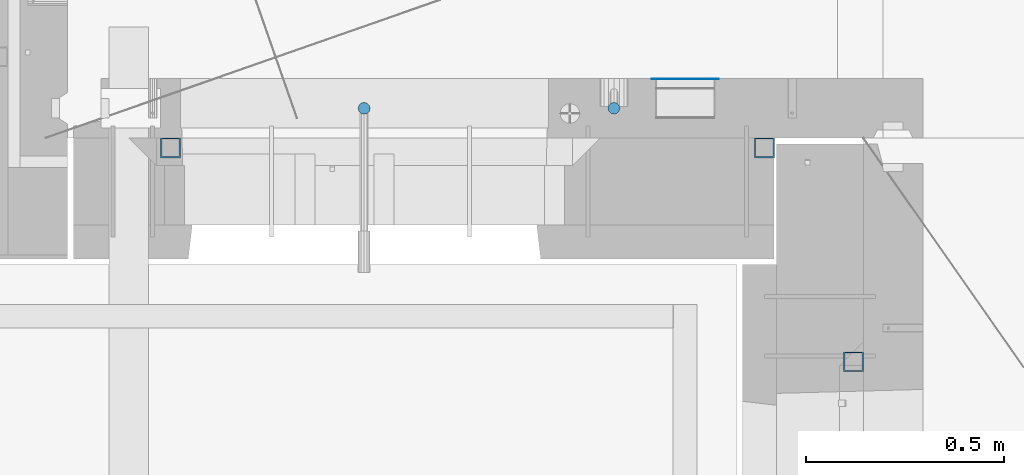
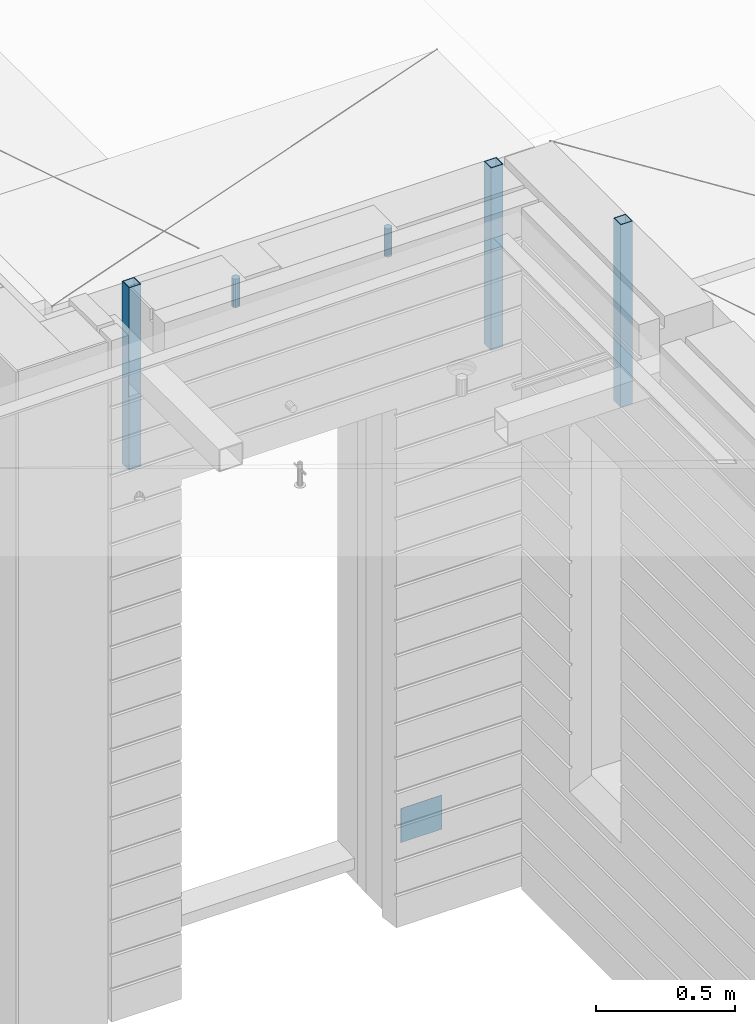
# One storey, part 11 of 334: 6 columns, 6 elements without a shape of their own.
"""IFC2X3 building model written with IfcOpenShell, lengths in millimetres."""

import ifcopenshell
import ifcopenshell.guid

model = None  # the IFC model being written
_history = None  # IfcOwnerHistory: only IFC2X3 demands one
_inside = {}  # id of a spatial element -> (the spatial element, [elements in it])
_under = {}  # id of a project, library or spatial element -> (it, [spatial elements below it])
_declared = {}  # id of a project -> (the project, [libraries it declares])
_typed = {}  # id of a type object -> (the type object, [elements of that type])
_made_of = {}  # id of a material, layer set ... -> (it, [elements and type objects made of it])


def new_model(schema):
    """Start an empty IFC model of exactly this schema.

    Asked for "IFC4X3", IfcOpenShell would pick the latest addendum, in which some entities
    have other attributes; the version numbers below select the first issue.
    IFC2X3 requires an IfcOwnerHistory on every rooted entity: one is made here for all.
    """
    global model, _history
    if schema == "IFC4X3":
        model = ifcopenshell.file(schema_version=(4, 3, 0, 0))
    else:
        model = ifcopenshell.file(schema=schema)
    _inside.clear()
    _under.clear()
    _declared.clear()
    _typed.clear()
    _made_of.clear()
    _history = None
    if model.schema == "IFC2X3":
        org = make("IfcOrganization", Name="unknown")
        user = make(
            "IfcPersonAndOrganization",
            ThePerson=make("IfcPerson", FamilyName="unknown"),
            TheOrganization=org,
        )
        app = make(
            "IfcApplication",
            ApplicationDeveloper=org,
            Version="unknown",
            ApplicationFullName="unknown",
            ApplicationIdentifier="unknown",
        )
        _history = make(
            "IfcOwnerHistory",
            OwningUser=user,
            OwningApplication=app,
            ChangeAction="ADDED",
            CreationDate=0,
        )
    return model


def make(cls, **values):
    """One entity of the class cls with the attributes given. An attribute that is None is left unset."""
    return model.create_entity(
        cls, **{name: value for name, value in values.items() if value is not None}
    )


def rooted(cls, **values):
    """An entity with a GlobalId (a new one), such as an element, a storey or a relation."""
    return make(cls, GlobalId=ifcopenshell.guid.new(), OwnerHistory=_history, **values)


def si_unit(unit_type, name, prefix=None):
    """IfcSIUnit, for example si_unit("LENGTHUNIT", "METRE", prefix="MILLI")."""
    return make("IfcSIUnit", UnitType=unit_type, Prefix=prefix, Name=name)


def assignment(units):
    """IfcUnitAssignment: the units of a project."""
    return None if units is None else make("IfcUnitAssignment", Units=units)


def point(xyz):
    """IfcCartesianPoint."""
    return None if xyz is None else make("IfcCartesianPoint", Coordinates=xyz)


def direction(xyz):
    """IfcDirection."""
    return None if xyz is None else make("IfcDirection", DirectionRatios=xyz)


def frame(location, z_axis=None, x_axis=None):
    """IfcAxis2Placement3D, a coordinate frame: its origin and axes. An axis left out is left unset."""
    return make(
        "IfcAxis2Placement3D",
        Location=point(location),
        Axis=direction(z_axis),
        RefDirection=direction(x_axis),
    )


def origin_with_axes():
    """The frame at (0, 0, 0) with the z axis (0, 0, 1) and the x axis (1, 0, 0) written out."""
    return frame((0.0, 0.0, 0.0), z_axis=(0.0, 0.0, 1.0), x_axis=(1.0, 0.0, 0.0))


def place(relative_to, where):
    """IfcLocalPlacement: puts the frame where relative to a parent placement (None: the world)."""
    return make(
        "IfcLocalPlacement", PlacementRelTo=relative_to, RelativePlacement=where
    )


def context(
    kind, dimensions, precision=None, world=None, true_north=None, identifier=None
):
    """IfcGeometricRepresentationContext, for example the 3D "Model" context."""
    return make(
        "IfcGeometricRepresentationContext",
        ContextIdentifier=identifier,
        ContextType=kind,
        CoordinateSpaceDimension=dimensions,
        Precision=precision,
        WorldCoordinateSystem=world,
        TrueNorth=true_north,
    )


def subcontext(parent, identifier, kind, view, scale=None):
    """IfcGeometricRepresentationSubContext, for example "Body" below "Model"."""
    return make(
        "IfcGeometricRepresentationSubContext",
        ContextIdentifier=identifier,
        ContextType=kind,
        ParentContext=parent,
        TargetScale=scale,
        TargetView=view,
    )


def project(units=None, contexts=None):
    """IfcProject with its units and contexts."""
    return rooted(
        "IfcProject",
        Name="project",
        RepresentationContexts=contexts,
        UnitsInContext=assignment(units),
    )


def spatial(cls, under=None, at=None, **own):
    """A site, building, storey or space (cls), placed at a placement, below another one or the project."""
    s = rooted(cls, ObjectPlacement=at, **own)
    if under is not None:
        _under.setdefault(under.id(), (under, []))[1].append(s)
    return s


def faces_of(points, faces, orient=None, outer=None):
    """IfcFace entities. A face is a list of loops; a loop is a list of indices into points, from 0.

    orient and outer hold one flag for each loop. By default every Orientation is true, the
    first loop of a face is its IfcFaceOuterBound and the others are IfcFaceBound.
    """
    made = []
    for i, loops in enumerate(faces):
        bounds = []
        for j, loop in enumerate(loops):
            is_outer = j == 0 if outer is None else outer[i][j]
            bounds.append(
                make(
                    "IfcFaceOuterBound" if is_outer else "IfcFaceBound",
                    Bound=make("IfcPolyLoop", Polygon=[points[k] for k in loop]),
                    Orientation=True if orient is None else orient[i][j],
                )
            )
        made.append(make("IfcFace", Bounds=bounds))
    return made


def faceted_brep(points, faces, orient=None, outer=None, voids=None):
    """IfcFacetedBrep: a solid bounded by flat faces; with voids (closed shells), ...WithVoids."""
    shared = [point(p) for p in points]
    hull = make("IfcClosedShell", CfsFaces=faces_of(shared, faces, orient, outer))
    if voids is None:
        return make("IfcFacetedBrep", Outer=hull)
    return make(
        "IfcFacetedBrepWithVoids",
        Outer=hull,
        Voids=[
            make(cls, CfsFaces=faces_of(shared, fs, o, b)) for cls, fs, o, b in voids
        ],
    )


def shape(context_of_items, identifier, shape_type, items):
    """IfcShapeRepresentation: the items that make up one representation, for example the "Body"."""
    return make(
        "IfcShapeRepresentation",
        ContextOfItems=context_of_items,
        RepresentationIdentifier=identifier,
        RepresentationType=shape_type,
        Items=items,
    )


def material(Name=None, Category=None):
    """IfcMaterial."""
    return make("IfcMaterial", Name=Name, Category=Category)


def made_of(thing, what):
    """Note that an element or type object is made of a material, layer set ...; save() writes the relation."""
    if what is not None:
        _made_of.setdefault(what.id(), (what, []))[1].append(thing)
    return thing


def type_object(cls, material=None, **own):
    """A type object (cls), such as IfcWallType, which elements share."""
    return made_of(rooted(cls, **own), material)


def element(
    cls,
    number,
    at=None,
    inside=None,
    cuts=None,
    type_object=None,
    material=None,
    context=None,
    identifier="Body",
    shape_type=None,
    held_by="IfcProductDefinitionShape",
    body=None,
    shapes=None,
    **own,
):
    """One element of the class cls, such as IfcWall. Its Tag is "e" and its number.

    at: its placement. inside: the storey or other place that contains it. cuts: it is an
    opening in that element (IfcRelVoidsElement). A single representation is given by context,
    identifier, shape_type and body (its items); several are given by shapes. held_by: the class
    of the entity that holds the representations. save() writes the other relations.
    """
    e = rooted(cls, Tag="e%d" % number, ObjectPlacement=at, **own)
    if body is not None:
        shapes = [shape(context, identifier, shape_type, body)]
    if shapes is not None:
        e.Representation = make(held_by, Representations=shapes)
    if inside is not None:
        _inside.setdefault(inside.id(), (inside, []))[1].append(e)
    if cuts is not None:
        rooted(
            "IfcRelVoidsElement", RelatingBuildingElement=cuts, RelatedOpeningElement=e
        )
    if type_object is not None:
        _typed.setdefault(type_object.id(), (type_object, []))[1].append(e)
    return made_of(e, material)


def aggregate(whole, parts):
    """IfcRelAggregates: a whole, such as a stair, and the parts it consists of."""
    return rooted("IfcRelAggregates", RelatingObject=whole, RelatedObjects=parts)


def save(model, path):
    """Write the relations noted so far, then the file.

    IfcRelAggregates (storeys below a building ...), IfcRelContainedInSpatialStructure (elements
    in a storey), IfcRelDefinesByType, IfcRelAssociatesMaterial and IfcRelDeclares: one each for
    every whole, place, type object, material and project.
    """
    for whole, parts in _under.values():
        aggregate(whole, parts)
    for where, things in _inside.values():
        rooted(
            "IfcRelContainedInSpatialStructure",
            RelatedElements=things,
            RelatingStructure=where,
        )
    for kind, things in _typed.values():
        rooted("IfcRelDefinesByType", RelatedObjects=things, RelatingType=kind)
    for what, things in _made_of.values():
        rooted("IfcRelAssociatesMaterial", RelatedObjects=things, RelatingMaterial=what)
    for by, libraries in _declared.values():
        rooted("IfcRelDeclares", RelatingContext=by, RelatedDefinitions=libraries)
    model.write(path)


model = new_model("IFC2X3")

# Units and contexts
model_context = context("Model", 3, precision=1e-05, world=origin_with_axes())
body_context = subcontext(model_context, "Body", "Model", "MODEL_VIEW")
ifc_project = project(units=[si_unit("LENGTHUNIT", "METRE", prefix="MILLI"), si_unit("AREAUNIT", "SQUARE_METRE"), si_unit("VOLUMEUNIT", "CUBIC_METRE"), si_unit("MASSUNIT", "GRAM", prefix="KILO"), si_unit("TIMEUNIT", "SECOND"), si_unit("PLANEANGLEUNIT", "RADIAN"), si_unit("SOLIDANGLEUNIT", "STERADIAN"), si_unit("THERMODYNAMICTEMPERATUREUNIT", "DEGREE_CELSIUS"), si_unit("LUMINOUSINTENSITYUNIT", "LUMEN")], contexts=[model_context])

# Site, building, storey
site_placement = place(None, origin_with_axes())
site = spatial("IfcSite", under=ifc_project, at=site_placement, CompositionType="ELEMENT")
building_placement = place(site_placement, origin_with_axes())
building = spatial("IfcBuilding", under=site, at=building_placement, CompositionType="ELEMENT")
storey_placement = place(building_placement, origin_with_axes())
storey = spatial("IfcBuildingStorey", under=building, at=storey_placement, Name="3", CompositionType="ELEMENT", Elevation=0.0)

# Assemblies, columns
assembly_1_placement = place(storey_placement, origin_with_axes())
assembly_1 = element("IfcElementAssembly", 1, at=assembly_1_placement, inside=storey, AssemblyPlace="NOTDEFINED", PredefinedType="REINFORCEMENT_UNIT")
ifc_material_1 = material()
column_type_1 = type_object("IfcColumnType", Name="D30", PredefinedType="NOTDEFINED")
column_1_placement = place(assembly_1_placement, frame((9379.99827996565, 11025.0, 90407.5), z_axis=(0.0, -1.0, 0.0), x_axis=(0.0, 0.0, 1.0)))
column_1 = element("IfcColumn", 2, at=column_1_placement, type_object=column_type_1, material=ifc_material_1, ObjectType="D30", context=body_context, shape_type="Brep", body=[
    faceted_brep([(0.0, -15.0, 0.0), (0.0, -12.9903810567666, -7.5), (125.0, -12.9903810567666, -7.5), (125.0, -15.0, 0.0), (0.0, -7.5, -12.9903810567666), (125.0, -7.5, -12.9903810567666), (0.0, 0.0, -15.0), (125.0, 0.0, -15.0), (0.0, 7.5, -12.9903810567666), (125.0, 7.5, -12.9903810567666), (0.0, 12.9903810567666, -7.5), (125.0, 12.9903810567666, -7.5), (0.0, 15.0, 0.0), (125.0, 15.0, 0.0), (0.0, 12.9903810567666, 7.5), (125.0, 12.9903810567666, 7.5), (0.0, 7.5, 12.9903810567666), (125.0, 7.5, 12.9903810567666), (0.0, 0.0, 15.0), (125.0, 0.0, 15.0), (0.0, -7.5, 12.9903810567666), (125.0, -7.5, 12.9903810567666), (0.0, -12.9903810567666, 7.5), (125.0, -12.9903810567666, 7.5)], [[[0, 1, 2, 3]], [[1, 4, 5, 2]], [[4, 6, 7, 5]], [[6, 8, 9, 7]], [[8, 10, 11, 9]], [[10, 12, 13, 11]], [[12, 14, 15, 13]], [[14, 16, 17, 15]], [[16, 18, 19, 17]], [[18, 20, 21, 19]], [[20, 22, 23, 21]], [[22, 0, 3, 23]], [[5, 7, 9, 11, 13, 15, 17, 19, 21, 23, 3, 2]], [[22, 20, 18, 16, 14, 12, 10, 8, 6, 4, 1, 0]]]),
])
column_2_placement = place(assembly_1_placement, frame((8748.99633326467, 11025.0000000071, 90407.5), z_axis=(0.0, 1.0, 0.0), x_axis=(0.0, 0.0, 1.0)))
column_2 = element("IfcColumn", 3, at=column_2_placement, type_object=column_type_1, material=ifc_material_1, ObjectType="D30", context=body_context, shape_type="Brep", body=[
    faceted_brep([(0.0, -15.0, 0.0), (0.0, -12.9903810567666, -7.5), (125.0, -12.9903810567666, -7.5), (125.0, -15.0, 0.0), (0.0, -7.5, -12.9903810567666), (125.0, -7.5, -12.9903810567666), (0.0, 0.0, -15.0), (125.0, 0.0, -15.0), (0.0, 7.5, -12.9903810567666), (125.0, 7.5, -12.9903810567666), (0.0, 12.9903810567666, -7.5), (125.0, 12.9903810567666, -7.5), (0.0, 15.0, 0.0), (125.0, 15.0, 0.0), (0.0, 12.9903810567666, 7.5), (125.0, 12.9903810567666, 7.5), (0.0, 7.5, 12.9903810567666), (125.0, 7.5, 12.9903810567666), (0.0, 0.0, 15.0), (125.0, 0.0, 15.0), (0.0, -7.5, 12.9903810567666), (125.0, -7.5, 12.9903810567666), (0.0, -12.9903810567666, 7.5), (125.0, -12.9903810567666, 7.5)], [[[0, 1, 2, 3]], [[1, 4, 5, 2]], [[4, 6, 7, 5]], [[6, 8, 9, 7]], [[8, 10, 11, 9]], [[10, 12, 13, 11]], [[12, 14, 15, 13]], [[14, 16, 17, 15]], [[16, 18, 19, 17]], [[18, 20, 21, 19]], [[20, 22, 23, 21]], [[22, 0, 3, 23]], [[5, 7, 9, 11, 13, 15, 17, 19, 21, 23, 3, 2]], [[22, 20, 18, 16, 14, 12, 10, 8, 6, 4, 1, 0]]]),
])
assembly_2_placement = place(assembly_1_placement, origin_with_axes())
assembly_2 = element("IfcElementAssembly", 4, at=assembly_2_placement, Name="Steel Assembly", AssemblyPlace="NOTDEFINED", PredefinedType="NOTDEFINED")
ifc_material_2 = material(Name="Undefined")
column_type_2 = type_object("IfcColumnType", PredefinedType="NOTDEFINED")
column_3_placement = place(assembly_2_placement, frame((9560.0000000031, 11098.9999999984, 87754.9999999985), z_axis=(0.0, 1.0, 0.0), x_axis=(0.0, 0.0, 1.0)))
column_3 = element("IfcColumn", 5, at=column_3_placement, type_object=column_type_2, material=ifc_material_2, Name="SPK2", context=body_context, shape_type="Brep", body=[
    faceted_brep([(0.0, 85.0, -1.0), (0.0, 85.0, 1.0), (150.0, 85.0, 1.0), (150.0, 85.0, -1.0), (0.0, -85.0, 1.0), (150.0, -85.0, 1.0), (0.0, -85.0, -1.0), (150.0, -85.0, -1.0)], [[[0, 1, 2, 3]], [[1, 4, 5, 2]], [[4, 6, 7, 5]], [[6, 0, 3, 7]], [[5, 7, 3, 2]], [[6, 4, 1, 0]]]),
])
aggregate(assembly_2, [column_3])
assembly_3_placement = place(assembly_1_placement, origin_with_axes())
assembly_3 = element("IfcElementAssembly", 6, at=assembly_3_placement, Name="Steel Assembly", AssemblyPlace="NOTDEFINED", PredefinedType="RIGID_FRAME")
ifc_material_3 = material(Name="STEEL/S355J2")
column_type_3 = type_object("IfcColumnType", Name="50X50X3", PredefinedType="NOTDEFINED")
column_4_placement = place(assembly_3_placement, frame((8260.0, 10925.0, 89940.0), z_axis=(1.0, 0.0, 0.0), x_axis=(0.0, 0.0, 1.0)))
column_4 = element("IfcColumn", 7, at=column_4_placement, type_object=column_type_3, material=ifc_material_3, ObjectType="50X50X3", context=body_context, shape_type="Brep", body=[
    faceted_brep([(0.0, 22.0, -22.0), (0.0, -22.0, -22.0), (800.0, -22.0, -22.0), (800.0, 22.0, -22.0), (0.0, -22.0, 22.0), (800.0, -22.0, 22.0), (0.0, 22.0, 22.0), (800.0, 22.0, 22.0), (0.0, 25.0, -25.0), (0.0, 25.0, 25.0), (800.0, 25.0, 25.0), (800.0, 25.0, -25.0), (0.0, -25.0, 25.0), (800.0, -25.0, 25.0), (0.0, -25.0, -25.0), (800.0, -25.0, -25.0)], [[[0, 1, 2, 3]], [[1, 4, 5, 2]], [[4, 6, 7, 5]], [[6, 0, 3, 7]], [[8, 9, 10, 11]], [[9, 12, 13, 10]], [[12, 14, 15, 13]], [[14, 8, 11, 15]], [[13, 15, 11, 10], [5, 7, 3, 2]], [[14, 12, 9, 8], [6, 4, 1, 0]]]),
])
aggregate(assembly_3, [column_4])
assembly_4_placement = place(assembly_1_placement, origin_with_axes())
assembly_4 = element("IfcElementAssembly", 8, at=assembly_4_placement, Name="Steel Assembly", AssemblyPlace="NOTDEFINED", PredefinedType="RIGID_FRAME")
aggregate(assembly_1, [column_1, column_2, assembly_2, assembly_3, assembly_4])
column_5_placement = place(assembly_4_placement, frame((9760.0, 10925.0, 89940.0), z_axis=(1.0, 0.0, 0.0), x_axis=(0.0, 0.0, 1.0)))
column_5 = element("IfcColumn", 9, at=column_5_placement, type_object=column_type_3, material=ifc_material_3, ObjectType="50X50X3", context=body_context, shape_type="Brep", body=[
    faceted_brep([(0.0, 22.0, -22.0), (0.0, -22.0, -22.0), (800.0, -22.0, -22.0), (800.0, 22.0, -22.0), (0.0, -22.0, 22.0), (800.0, -22.0, 22.0), (0.0, 22.0, 22.0), (800.0, 22.0, 22.0), (0.0, 25.0, -25.0), (0.0, 25.0, 25.0), (800.0, 25.0, 25.0), (800.0, 25.0, -25.0), (0.0, -25.0, 25.0), (800.0, -25.0, 25.0), (0.0, -25.0, -25.0), (800.0, -25.0, -25.0)], [[[0, 1, 2, 3]], [[1, 4, 5, 2]], [[4, 6, 7, 5]], [[6, 0, 3, 7]], [[8, 9, 10, 11]], [[9, 12, 13, 10]], [[12, 14, 15, 13]], [[14, 8, 11, 15]], [[13, 15, 11, 10], [5, 7, 3, 2]], [[14, 12, 9, 8], [6, 4, 1, 0]]]),
])
aggregate(assembly_4, [column_5])

# Assemblies, column
assembly_5_placement = place(storey_placement, origin_with_axes())
assembly_5 = element("IfcElementAssembly", 10, at=assembly_5_placement, inside=storey, AssemblyPlace="NOTDEFINED", PredefinedType="REINFORCEMENT_UNIT")
assembly_6_placement = place(assembly_5_placement, origin_with_axes())
assembly_6 = element("IfcElementAssembly", 11, at=assembly_6_placement, Name="Steel Assembly", AssemblyPlace="NOTDEFINED", PredefinedType="RIGID_FRAME")
aggregate(assembly_5, [assembly_6])
column_6_placement = place(assembly_6_placement, frame((9985.0, 10385.0, 89940.0), z_axis=(0.0, 1.0, 0.0), x_axis=(0.0, 0.0, 1.0)))
column_6 = element("IfcColumn", 12, at=column_6_placement, type_object=column_type_3, material=ifc_material_3, ObjectType="50X50X3", context=body_context, shape_type="Brep", body=[
    faceted_brep([(0.0, 22.0, -22.0), (0.0, -22.0, -22.0), (800.0, -22.0, -22.0), (800.0, 22.0, -22.0), (0.0, -22.0, 22.0), (800.0, -22.0, 22.0), (0.0, 22.0, 22.0), (800.0, 22.0, 22.0), (0.0, 25.0, -25.0), (0.0, 25.0, 25.0), (800.0, 25.0, 25.0), (800.0, 25.0, -25.0), (0.0, -25.0, 25.0), (800.0, -25.0, 25.0), (0.0, -25.0, -25.0), (800.0, -25.0, -25.0)], [[[0, 1, 2, 3]], [[1, 4, 5, 2]], [[4, 6, 7, 5]], [[6, 0, 3, 7]], [[8, 9, 10, 11]], [[9, 12, 13, 10]], [[12, 14, 15, 13]], [[14, 8, 11, 15]], [[13, 15, 11, 10], [5, 7, 3, 2]], [[14, 12, 9, 8], [6, 4, 1, 0]]]),
])
aggregate(assembly_6, [column_6])

save(model, "model.ifc")
